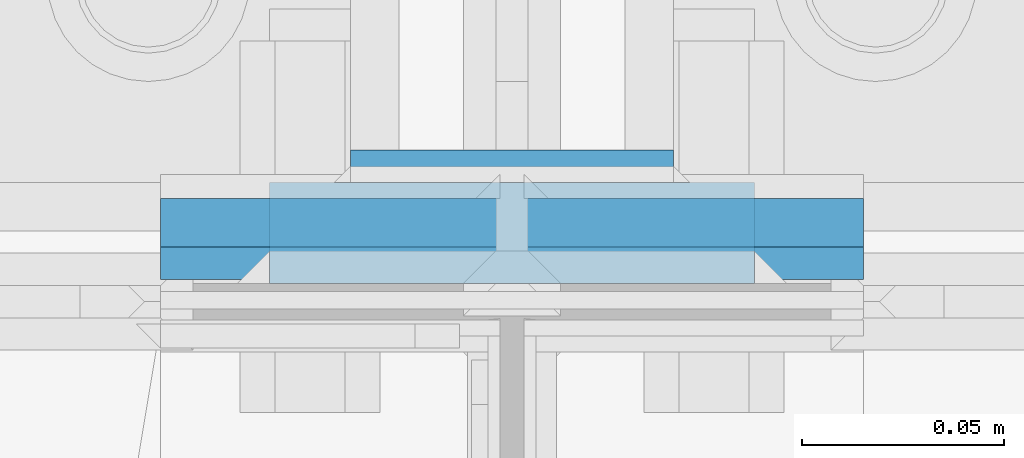
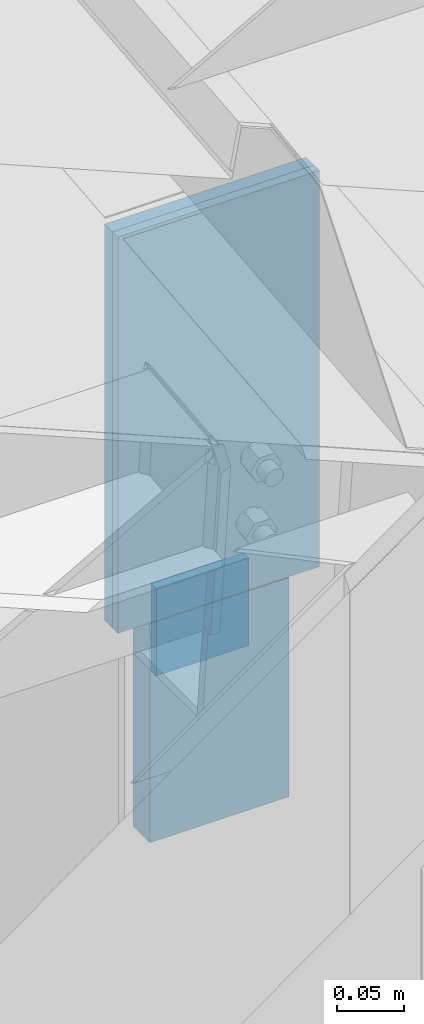
# One storey, part 25 of 709: 4 columns, 3 elements without a shape of their own.
"""IFC4 building model written with IfcOpenShell, lengths in millimetres."""

from ifc_helpers import new_model, si_unit, direction, frame, origin_with_axes, place, context, subcontext, project, spatial, line, indexed_curve, outline, extrude, material, element, aggregate, save


model = new_model("IFC4")

# Units and contexts
model_context = context("Model", 3, precision=0.2, world=origin_with_axes(), true_north=direction((0.0, 1.0)))
body_context = subcontext(model_context, "Body", "Model", "MODEL_VIEW")
ifc_project = project(units=[si_unit("LENGTHUNIT", "METRE", prefix="MILLI"), si_unit("AREAUNIT", "SQUARE_METRE"), si_unit("VOLUMEUNIT", "CUBIC_METRE"), si_unit("MASSUNIT", "GRAM", prefix="KILO"), si_unit("TIMEUNIT", "SECOND"), si_unit("PLANEANGLEUNIT", "RADIAN"), si_unit("SOLIDANGLEUNIT", "STERADIAN"), si_unit("THERMODYNAMICTEMPERATUREUNIT", "DEGREE_CELSIUS"), si_unit("LUMINOUSINTENSITYUNIT", "LUMEN")], contexts=[model_context])

# Site, building, storey
site_placement = place(None, origin_with_axes())
site = spatial("IfcSite", under=ifc_project, at=site_placement, CompositionType="ELEMENT")
building_placement = place(site_placement, origin_with_axes())
building = spatial("IfcBuilding", under=site, at=building_placement, Name="Undefined", CompositionType="ELEMENT")
storey_placement = place(building_placement, origin_with_axes())
storey = spatial("IfcBuildingStorey", under=building, at=storey_placement, Name="Undefined", CompositionType="ELEMENT", Elevation=0.0)

# Assembly, columns
assembly_1_placement = place(storey_placement, frame((46000.0, 173.0, -200.0), z_axis=(-1.0, 0.0, 0.0), x_axis=(0.0, 0.0, 1.0)))
assembly_1 = element("IfcElementAssembly", 1, at=assembly_1_placement, inside=storey)
ifc_material = material(Name="C355-6", Category="STEEL")
column_1_placement = place(assembly_1_placement, frame((6897.93718, 185.5, 0.0), z_axis=(0.0, 1.0, 0.0), x_axis=(1.0, 0.0, 0.0)))
column_1 = element("IfcColumn", 2, at=column_1_placement, material=ifc_material, ObjectType="459", context=body_context, shape_type="SolidModel", body=[
    extrude(outline(indexed_curve([(-12.5, -60.0), (12.5, -60.0), (12.5, 60.0), (-12.5, 60.0)], segments=[line(1, 2, 3, 4, 1)])), frame((0.0, 0.0, 0.0), z_axis=(-1.0, 0.0, 0.0), x_axis=(0.0, 0.0, 1.0)), (0.0, 0.0, -1.0), 200.0),
])
column_2_placement = place(assembly_1_placement, frame((7027.93718, 202.0, 0.0), z_axis=(0.0, 1.0, 0.0), x_axis=(1.0, 0.0, 0.0)))
column_2 = element("IfcColumn", 3, at=column_2_placement, material=ifc_material, ObjectType="462", context=body_context, shape_type="SolidModel", body=[
    extrude(outline(indexed_curve([(-4.0, -40.0), (4.0, -40.0), (4.0, 40.0), (-4.0, 40.0)], segments=[line(1, 2, 3, 4, 1)])), frame((0.0, 0.0, 0.0), z_axis=(-1.0, 0.0, 0.0), x_axis=(0.0, 0.0, 1.0)), (0.0, 0.0, -1.0), 80.0),
])
aggregate(assembly_1, [column_1, column_2])

# Assembly, column
assembly_2_placement = place(storey_placement, frame((46000.0, 346.0, 7089.70002), z_axis=(1.0, 0.0, 0.0), x_axis=(0.0, 0.9950371902, 0.099503719)))
assembly_2 = element("IfcElementAssembly", 4, at=assembly_2_placement, inside=storey)
column_3_placement = place(assembly_2_placement, frame((-4.15556, -192.30372, 0.0), z_axis=(0.9950371902, -0.099503719, 0.0), x_axis=(0.099503719, 0.9950371902, 0.0)))
column_3 = element("IfcColumn", 5, at=column_3_placement, material=ifc_material, ObjectType="457", context=body_context, shape_type="SolidModel", body=[
    extrude(outline(indexed_curve([(-6.0, -87.0), (6.0, -87.0), (6.0, 87.0), (-6.0, 87.0)], segments=[line(1, 2, 3, 4, 1)])), frame((0.0, 0.0, 0.0), z_axis=(-1.0, 0.0, 0.0), x_axis=(0.0, 0.0, 1.0)), (0.0, 0.0, -1.0), 361.7257),
])
aggregate(assembly_2, [column_3])

assembly_3_placement = place(storey_placement, frame((46000.0, 351.0, 6897.93718), z_axis=(0.0, 1.0, 0.0), x_axis=(0.0, 0.0, 1.0)))
assembly_3 = element("IfcElementAssembly", 6, at=assembly_3_placement, inside=storey)
column_4_placement = place(assembly_3_placement, origin_with_axes())
column_4 = element("IfcColumn", 7, at=column_4_placement, material=ifc_material, ObjectType="458", context=body_context, shape_type="SolidModel", body=[
    extrude(outline(indexed_curve([(-4.0, -87.0), (4.0, -87.0), (4.0, 87.0), (-4.0, 87.0)], segments=[line(1, 2, 3, 4, 1)])), frame((0.0, 0.0, 0.0), z_axis=(-1.0, 0.0, 0.0), x_axis=(0.0, 0.0, 1.0)), (0.0, 0.0, -1.0), 361.7257),
])
aggregate(assembly_3, [column_4])

save(model, "model.ifc")
